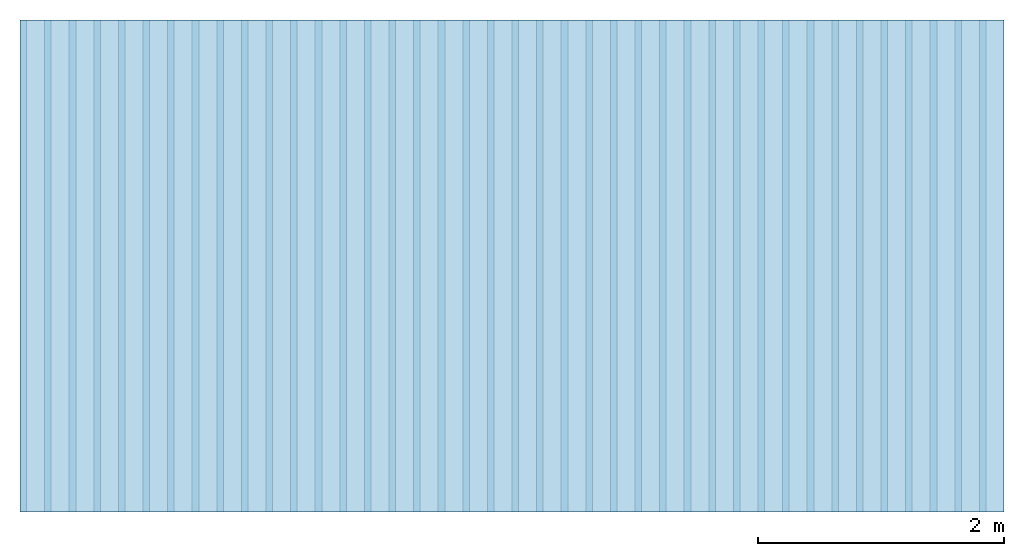
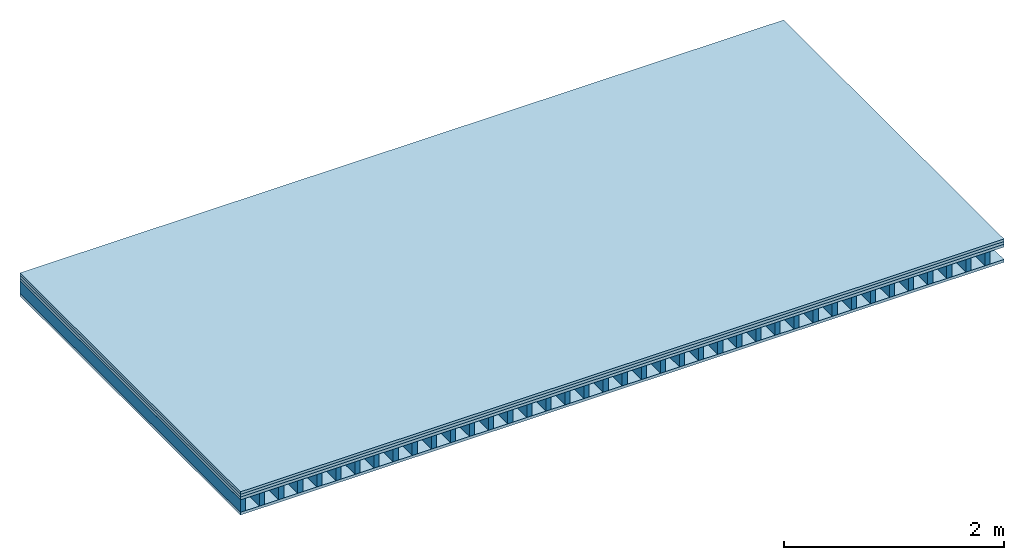
# One storey: 4 plates, 1 member, 1 element without a shape of its own.
"""IFC4 building model written with IfcOpenShell, lengths in metres."""

from ifc_helpers import new_model, si_unit, derived_unit, direction, frame, frame_2d, origin, origin_with_axes, place, context, project, spatial, rectangle, extrude, material, layer, layer_set, type_object, element, aggregate, save


model = new_model("IFC4")

# Units and contexts
plan_context = context("Plan", 3, precision=1e-05, world=origin(), true_north=direction((0.0, 1.0)))
model_context = context("Model", 3, precision=1e-05, world=origin(), true_north=direction((0.0, 1.0)))
ifc_project = project(units=[si_unit("LENGTHUNIT", "METRE"), derived_unit("SOUNDPRESSUREUNIT", [(si_unit("PRESSUREUNIT", "PASCAL", prefix="MICRO"), 0)]), si_unit("ENERGYUNIT", "JOULE", prefix="MEGA"), si_unit("MASSUNIT", "GRAM", prefix="KILO"), derived_unit("THERMALTRANSMITTANCEUNIT", [(si_unit("POWERUNIT", "WATT"), 1), (si_unit("AREAUNIT", "SQUARE_METRE"), -1), (si_unit("THERMODYNAMICTEMPERATUREUNIT", "KELVIN"), -1)]), derived_unit("AREADENSITYUNIT", [(si_unit("MASSUNIT", "GRAM", prefix="KILO"), 1), (si_unit("AREAUNIT", "SQUARE_METRE"), -1)]), derived_unit("USERDEFINED", [(si_unit("ENERGYUNIT", "JOULE", prefix="MEGA"), 1), (si_unit("AREAUNIT", "SQUARE_METRE"), -1)])], contexts=[plan_context, model_context])

# Site, building, storey
site = spatial("IfcSite", under=ifc_project)
building_placement = place(None, origin())
building = spatial("IfcBuilding", under=site, at=building_placement)
storey_placement = place(building_placement, origin())
storey = spatial("IfcBuildingStorey", under=building, at=storey_placement)

# Slab, member, plates
ifc_material_1 = material(Name="Chipboard", Category="07.015")
ifc_layer_1 = layer(ifc_material_1, 0.028, Name="On-material")
ifc_material_2 = material(Name="EP2, 30mm")
ifc_layer_2 = layer(ifc_material_2, 0.03, Name="Impact sound insulation")
ifc_material_3 = material(Name="box-element sheathing above")
ifc_layer_3 = layer(ifc_material_3, 0.031, Name="Sub-floor")
ifc_layer_4 = layer(None, 0.138, Name="Supporting structure")
ifc_material_4 = material(Name="box-element sheathing below")
ifc_layer_5 = layer(ifc_material_4, 0.031, Name="Lower layer 1")
ifc_layer_set = layer_set([ifc_layer_1, ifc_layer_2, ifc_layer_3, ifc_layer_4, ifc_layer_5])
slab_type = type_object("IfcSlabType", Name="A0022", PredefinedType="NOTDEFINED", material=ifc_layer_set)
slab_placement = place(None, frame((0.0, 0.0, 0.0), z_axis=(0.0, 0.0, -1.0), x_axis=(1.0, 0.0, 0.0)))
slab = element("IfcSlab", 1, at=slab_placement, inside=storey, type_object=slab_type, material=ifc_layer_set, Name="Slab #1")
ifc_material_5 = material(Name="box-element LKE")
member_placement = place(slab_placement, origin())
member = element("IfcMember", 2, at=member_placement, material=ifc_material_5, Name="Supporting structure", context=plan_context, shape_type="SweptSolid", body=[
    extrude(rectangle(XDim=0.054, YDim=0.138, at=frame_2d((0.027, 0.069), x_axis=(1.0, 0.0))), frame((0.0, 4.0, 0.089), z_axis=(0.0, -1.0, 0.0), x_axis=(1.0, 0.0, 0.0)), (0.0, 0.0, 1.0), 4.0),
    extrude(rectangle(XDim=0.054, YDim=0.138, at=frame_2d((0.027, 0.069), x_axis=(1.0, 0.0))), frame((0.2, 4.0, 0.089), z_axis=(0.0, -1.0, 0.0), x_axis=(1.0, 0.0, 0.0)), (0.0, 0.0, 1.0), 4.0),
    extrude(rectangle(XDim=0.054, YDim=0.138, at=frame_2d((0.027, 0.069), x_axis=(1.0, 0.0))), frame((0.4, 4.0, 0.089), z_axis=(0.0, -1.0, 0.0), x_axis=(1.0, 0.0, 0.0)), (0.0, 0.0, 1.0), 4.0),
    extrude(rectangle(XDim=0.054, YDim=0.138, at=frame_2d((0.027, 0.069), x_axis=(1.0, 0.0))), frame((0.6, 4.0, 0.089), z_axis=(0.0, -1.0, 0.0), x_axis=(1.0, 0.0, 0.0)), (0.0, 0.0, 1.0), 4.0),
    extrude(rectangle(XDim=0.054, YDim=0.138, at=frame_2d((0.027, 0.069), x_axis=(1.0, 0.0))), frame((0.8, 4.0, 0.089), z_axis=(0.0, -1.0, 0.0), x_axis=(1.0, 0.0, 0.0)), (0.0, 0.0, 1.0), 4.0),
    extrude(rectangle(XDim=0.054, YDim=0.138, at=frame_2d((0.027, 0.069), x_axis=(1.0, 0.0))), frame((1.0, 4.0, 0.089), z_axis=(0.0, -1.0, 0.0), x_axis=(1.0, 0.0, 0.0)), (0.0, 0.0, 1.0), 4.0),
    extrude(rectangle(XDim=0.054, YDim=0.138, at=frame_2d((0.027, 0.069), x_axis=(1.0, 0.0))), frame((1.2, 4.0, 0.089), z_axis=(0.0, -1.0, 0.0), x_axis=(1.0, 0.0, 0.0)), (0.0, 0.0, 1.0), 4.0),
    extrude(rectangle(XDim=0.054, YDim=0.138, at=frame_2d((0.027, 0.069), x_axis=(1.0, 0.0))), frame((1.4, 4.0, 0.089), z_axis=(0.0, -1.0, 0.0), x_axis=(1.0, 0.0, 0.0)), (0.0, 0.0, 1.0), 4.0),
    extrude(rectangle(XDim=0.054, YDim=0.138, at=frame_2d((0.027, 0.069), x_axis=(1.0, 0.0))), frame((1.6, 4.0, 0.089), z_axis=(0.0, -1.0, 0.0), x_axis=(1.0, 0.0, 0.0)), (0.0, 0.0, 1.0), 4.0),
    extrude(rectangle(XDim=0.054, YDim=0.138, at=frame_2d((0.027, 0.069), x_axis=(1.0, 0.0))), frame((1.8, 4.0, 0.089), z_axis=(0.0, -1.0, 0.0), x_axis=(1.0, 0.0, 0.0)), (0.0, 0.0, 1.0), 4.0),
    extrude(rectangle(XDim=0.054, YDim=0.138, at=frame_2d((0.027, 0.069), x_axis=(1.0, 0.0))), frame((2.0, 4.0, 0.089), z_axis=(0.0, -1.0, 0.0), x_axis=(1.0, 0.0, 0.0)), (0.0, 0.0, 1.0), 4.0),
    extrude(rectangle(XDim=0.054, YDim=0.138, at=frame_2d((0.027, 0.069), x_axis=(1.0, 0.0))), frame((2.2, 4.0, 0.089), z_axis=(0.0, -1.0, 0.0), x_axis=(1.0, 0.0, 0.0)), (0.0, 0.0, 1.0), 4.0),
    extrude(rectangle(XDim=0.054, YDim=0.138, at=frame_2d((0.027, 0.069), x_axis=(1.0, 0.0))), frame((2.4, 4.0, 0.089), z_axis=(0.0, -1.0, 0.0), x_axis=(1.0, 0.0, 0.0)), (0.0, 0.0, 1.0), 4.0),
    extrude(rectangle(XDim=0.054, YDim=0.138, at=frame_2d((0.027, 0.069), x_axis=(1.0, 0.0))), frame((2.6, 4.0, 0.089), z_axis=(0.0, -1.0, 0.0), x_axis=(1.0, 0.0, 0.0)), (0.0, 0.0, 1.0), 4.0),
    extrude(rectangle(XDim=0.054, YDim=0.138, at=frame_2d((0.027, 0.069), x_axis=(1.0, 0.0))), frame((2.8, 4.0, 0.089), z_axis=(0.0, -1.0, 0.0), x_axis=(1.0, 0.0, 0.0)), (0.0, 0.0, 1.0), 4.0),
    extrude(rectangle(XDim=0.054, YDim=0.138, at=frame_2d((0.027, 0.069), x_axis=(1.0, 0.0))), frame((3.0, 4.0, 0.089), z_axis=(0.0, -1.0, 0.0), x_axis=(1.0, 0.0, 0.0)), (0.0, 0.0, 1.0), 4.0),
    extrude(rectangle(XDim=0.054, YDim=0.138, at=frame_2d((0.027, 0.069), x_axis=(1.0, 0.0))), frame((3.2, 4.0, 0.089), z_axis=(0.0, -1.0, 0.0), x_axis=(1.0, 0.0, 0.0)), (0.0, 0.0, 1.0), 4.0),
    extrude(rectangle(XDim=0.054, YDim=0.138, at=frame_2d((0.027, 0.069), x_axis=(1.0, 0.0))), frame((3.4, 4.0, 0.089), z_axis=(0.0, -1.0, 0.0), x_axis=(1.0, 0.0, 0.0)), (0.0, 0.0, 1.0), 4.0),
    extrude(rectangle(XDim=0.054, YDim=0.138, at=frame_2d((0.027, 0.069), x_axis=(1.0, 0.0))), frame((3.6, 4.0, 0.089), z_axis=(0.0, -1.0, 0.0), x_axis=(1.0, 0.0, 0.0)), (0.0, 0.0, 1.0), 4.0),
    extrude(rectangle(XDim=0.054, YDim=0.138, at=frame_2d((0.027, 0.069), x_axis=(1.0, 0.0))), frame((3.8, 4.0, 0.089), z_axis=(0.0, -1.0, 0.0), x_axis=(1.0, 0.0, 0.0)), (0.0, 0.0, 1.0), 4.0),
    extrude(rectangle(XDim=0.054, YDim=0.138, at=frame_2d((0.027, 0.069), x_axis=(1.0, 0.0))), frame((4.0, 4.0, 0.089), z_axis=(0.0, -1.0, 0.0), x_axis=(1.0, 0.0, 0.0)), (0.0, 0.0, 1.0), 4.0),
    extrude(rectangle(XDim=0.054, YDim=0.138, at=frame_2d((0.027, 0.069), x_axis=(1.0, 0.0))), frame((4.2, 4.0, 0.089), z_axis=(0.0, -1.0, 0.0), x_axis=(1.0, 0.0, 0.0)), (0.0, 0.0, 1.0), 4.0),
    extrude(rectangle(XDim=0.054, YDim=0.138, at=frame_2d((0.027, 0.069), x_axis=(1.0, 0.0))), frame((4.4, 4.0, 0.089), z_axis=(0.0, -1.0, 0.0), x_axis=(1.0, 0.0, 0.0)), (0.0, 0.0, 1.0), 4.0),
    extrude(rectangle(XDim=0.054, YDim=0.138, at=frame_2d((0.027, 0.069), x_axis=(1.0, 0.0))), frame((4.6, 4.0, 0.089), z_axis=(0.0, -1.0, 0.0), x_axis=(1.0, 0.0, 0.0)), (0.0, 0.0, 1.0), 4.0),
    extrude(rectangle(XDim=0.054, YDim=0.138, at=frame_2d((0.027, 0.069), x_axis=(1.0, 0.0))), frame((4.8, 4.0, 0.089), z_axis=(0.0, -1.0, 0.0), x_axis=(1.0, 0.0, 0.0)), (0.0, 0.0, 1.0), 4.0),
    extrude(rectangle(XDim=0.054, YDim=0.138, at=frame_2d((0.027, 0.069), x_axis=(1.0, 0.0))), frame((5.0, 4.0, 0.089), z_axis=(0.0, -1.0, 0.0), x_axis=(1.0, 0.0, 0.0)), (0.0, 0.0, 1.0), 4.0),
    extrude(rectangle(XDim=0.054, YDim=0.138, at=frame_2d((0.027, 0.069), x_axis=(1.0, 0.0))), frame((5.2, 4.0, 0.089), z_axis=(0.0, -1.0, 0.0), x_axis=(1.0, 0.0, 0.0)), (0.0, 0.0, 1.0), 4.0),
    extrude(rectangle(XDim=0.054, YDim=0.138, at=frame_2d((0.027, 0.069), x_axis=(1.0, 0.0))), frame((5.4, 4.0, 0.089), z_axis=(0.0, -1.0, 0.0), x_axis=(1.0, 0.0, 0.0)), (0.0, 0.0, 1.0), 4.0),
    extrude(rectangle(XDim=0.054, YDim=0.138, at=frame_2d((0.027, 0.069), x_axis=(1.0, 0.0))), frame((5.6, 4.0, 0.089), z_axis=(0.0, -1.0, 0.0), x_axis=(1.0, 0.0, 0.0)), (0.0, 0.0, 1.0), 4.0),
    extrude(rectangle(XDim=0.054, YDim=0.138, at=frame_2d((0.027, 0.069), x_axis=(1.0, 0.0))), frame((5.8, 4.0, 0.089), z_axis=(0.0, -1.0, 0.0), x_axis=(1.0, 0.0, 0.0)), (0.0, 0.0, 1.0), 4.0),
    extrude(rectangle(XDim=0.054, YDim=0.138, at=frame_2d((0.027, 0.069), x_axis=(1.0, 0.0))), frame((6.0, 4.0, 0.089), z_axis=(0.0, -1.0, 0.0), x_axis=(1.0, 0.0, 0.0)), (0.0, 0.0, 1.0), 4.0),
    extrude(rectangle(XDim=0.054, YDim=0.138, at=frame_2d((0.027, 0.069), x_axis=(1.0, 0.0))), frame((6.2, 4.0, 0.089), z_axis=(0.0, -1.0, 0.0), x_axis=(1.0, 0.0, 0.0)), (0.0, 0.0, 1.0), 4.0),
    extrude(rectangle(XDim=0.054, YDim=0.138, at=frame_2d((0.027, 0.069), x_axis=(1.0, 0.0))), frame((6.4, 4.0, 0.089), z_axis=(0.0, -1.0, 0.0), x_axis=(1.0, 0.0, 0.0)), (0.0, 0.0, 1.0), 4.0),
    extrude(rectangle(XDim=0.054, YDim=0.138, at=frame_2d((0.027, 0.069), x_axis=(1.0, 0.0))), frame((6.6, 4.0, 0.089), z_axis=(0.0, -1.0, 0.0), x_axis=(1.0, 0.0, 0.0)), (0.0, 0.0, 1.0), 4.0),
    extrude(rectangle(XDim=0.054, YDim=0.138, at=frame_2d((0.027, 0.069), x_axis=(1.0, 0.0))), frame((6.8, 4.0, 0.089), z_axis=(0.0, -1.0, 0.0), x_axis=(1.0, 0.0, 0.0)), (0.0, 0.0, 1.0), 4.0),
    extrude(rectangle(XDim=0.054, YDim=0.138, at=frame_2d((0.027, 0.069), x_axis=(1.0, 0.0))), frame((7.0, 4.0, 0.089), z_axis=(0.0, -1.0, 0.0), x_axis=(1.0, 0.0, 0.0)), (0.0, 0.0, 1.0), 4.0),
    extrude(rectangle(XDim=0.054, YDim=0.138, at=frame_2d((0.027, 0.069), x_axis=(1.0, 0.0))), frame((7.2, 4.0, 0.089), z_axis=(0.0, -1.0, 0.0), x_axis=(1.0, 0.0, 0.0)), (0.0, 0.0, 1.0), 4.0),
    extrude(rectangle(XDim=0.054, YDim=0.138, at=frame_2d((0.027, 0.069), x_axis=(1.0, 0.0))), frame((7.4, 4.0, 0.089), z_axis=(0.0, -1.0, 0.0), x_axis=(1.0, 0.0, 0.0)), (0.0, 0.0, 1.0), 4.0),
    extrude(rectangle(XDim=0.054, YDim=0.138, at=frame_2d((0.027, 0.069), x_axis=(1.0, 0.0))), frame((7.6, 4.0, 0.089), z_axis=(0.0, -1.0, 0.0), x_axis=(1.0, 0.0, 0.0)), (0.0, 0.0, 1.0), 4.0),
    extrude(rectangle(XDim=0.054, YDim=0.138, at=frame_2d((0.027, 0.069), x_axis=(1.0, 0.0))), frame((7.8, 4.0, 0.089), z_axis=(0.0, -1.0, 0.0), x_axis=(1.0, 0.0, 0.0)), (0.0, 0.0, 1.0), 4.0),
])
plate_1_placement = place(slab_placement, origin())
plate_1 = element("IfcPlate", 3, at=plate_1_placement, material=ifc_material_1, Name="On-material", context=plan_context, shape_type="SweptSolid", body=[
    extrude(rectangle(XDim=8.0, YDim=4.0, at=frame_2d((4.0, 2.0), x_axis=(1.0, 0.0))), origin_with_axes(), (0.0, 0.0, 1.0), 0.028),
])
plate_2_placement = place(slab_placement, origin())
plate_2 = element("IfcPlate", 4, at=plate_2_placement, material=ifc_material_2, Name="Impact sound insulation", context=plan_context, shape_type="SweptSolid", body=[
    extrude(rectangle(XDim=8.0, YDim=4.0, at=frame_2d((4.0, 2.0), x_axis=(1.0, 0.0))), frame((0.0, 0.0, 0.028), z_axis=(0.0, 0.0, 1.0), x_axis=(1.0, 0.0, 0.0)), (0.0, 0.0, 1.0), 0.03),
])
plate_3_placement = place(slab_placement, origin())
plate_3 = element("IfcPlate", 5, at=plate_3_placement, material=ifc_material_3, Name="Sub-floor", context=plan_context, shape_type="SweptSolid", body=[
    extrude(rectangle(XDim=8.0, YDim=4.0, at=frame_2d((4.0, 2.0), x_axis=(1.0, 0.0))), frame((0.0, 0.0, 0.058), z_axis=(0.0, 0.0, 1.0), x_axis=(1.0, 0.0, 0.0)), (0.0, 0.0, 1.0), 0.031),
])
plate_4_placement = place(slab_placement, origin())
plate_4 = element("IfcPlate", 6, at=plate_4_placement, material=ifc_material_4, Name="Lower layer 1", context=plan_context, shape_type="SweptSolid", body=[
    extrude(rectangle(XDim=8.0, YDim=4.0, at=frame_2d((4.0, 2.0), x_axis=(1.0, 0.0))), frame((0.0, 0.0, 0.227), z_axis=(0.0, 0.0, 1.0), x_axis=(1.0, 0.0, 0.0)), (0.0, 0.0, 1.0), 0.031),
])
aggregate(slab, [plate_1, plate_2, plate_3, member, plate_4])

save(model, "model.ifc")
